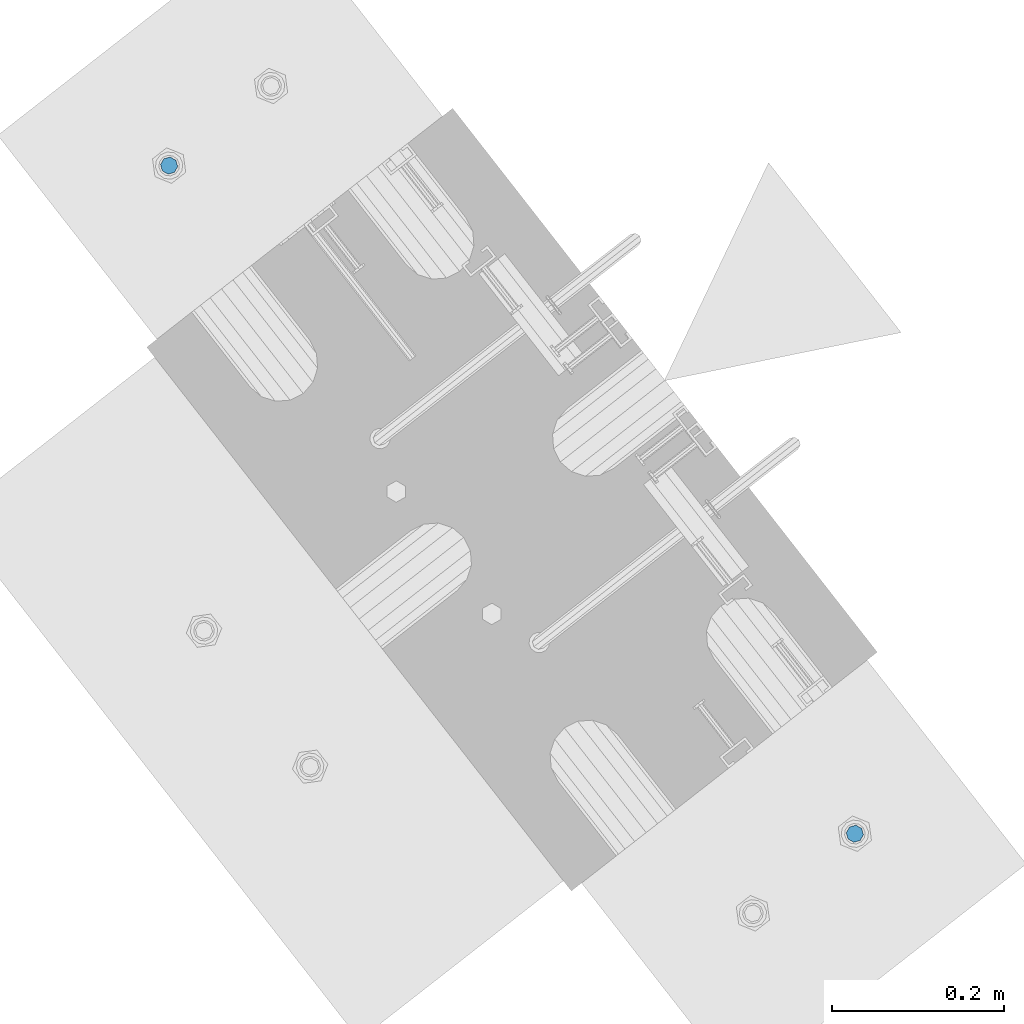
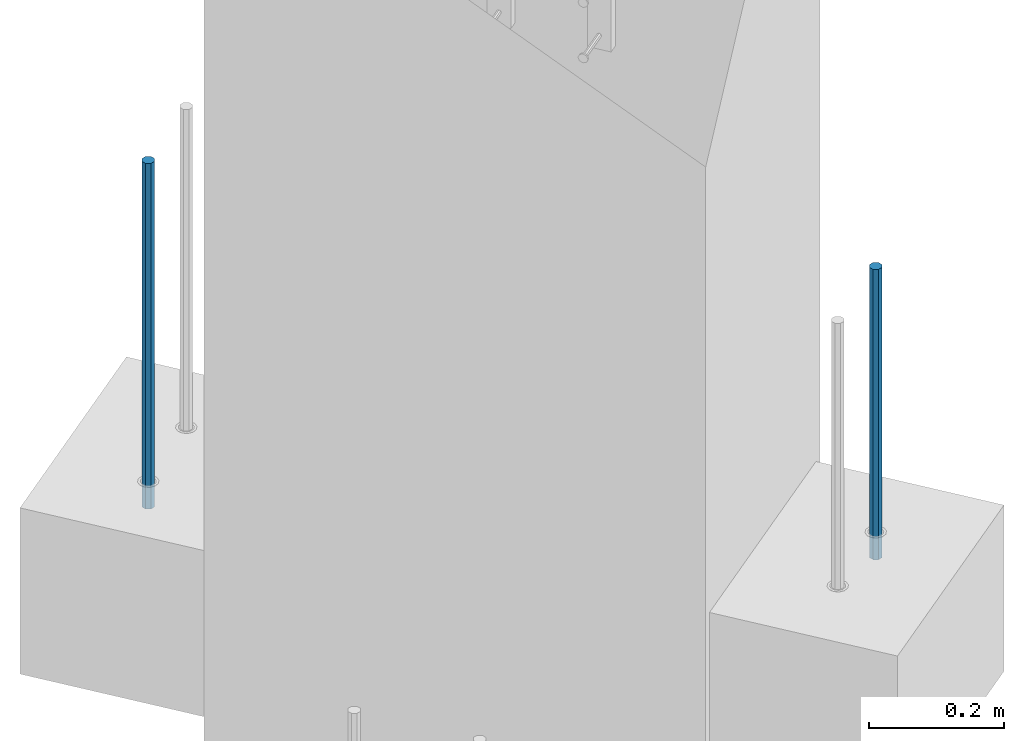
# One storey, part 10 of 42: 2 beams, 1 element without a shape of its own.
"""IFC2X3 building model written with IfcOpenShell, lengths in millimetres."""

from ifc_helpers import new_model, si_unit, frame, origin_with_axes, place, context, subcontext, project, spatial, faceted_brep, material, type_object, element, aggregate, save


model = new_model("IFC2X3")

# Units and contexts
model_context = context("Model", 3, precision=1e-05, world=origin_with_axes())
body_context = subcontext(model_context, "Body", "Model", "MODEL_VIEW")
ifc_project = project(units=[si_unit("LENGTHUNIT", "METRE", prefix="MILLI"), si_unit("AREAUNIT", "SQUARE_METRE"), si_unit("VOLUMEUNIT", "CUBIC_METRE"), si_unit("MASSUNIT", "GRAM", prefix="KILO"), si_unit("TIMEUNIT", "SECOND"), si_unit("PLANEANGLEUNIT", "RADIAN"), si_unit("SOLIDANGLEUNIT", "STERADIAN"), si_unit("THERMODYNAMICTEMPERATUREUNIT", "DEGREE_CELSIUS"), si_unit("LUMINOUSINTENSITYUNIT", "LUMEN")], contexts=[model_context])

# Site, building, storey
site_placement = place(None, frame((171687.4, 84828.52, 14700.0), z_axis=(0.0, 0.0, 1.0), x_axis=(1.0, 0.0, 0.0)))
site = spatial("IfcSite", under=ifc_project, at=site_placement, CompositionType="ELEMENT")
building_placement = place(site_placement, origin_with_axes())
building = spatial("IfcBuilding", under=site, at=building_placement, Name="Undefined", CompositionType="ELEMENT")
storey_placement = place(building_placement, origin_with_axes())
storey = spatial("IfcBuildingStorey", under=building, at=storey_placement, Name="Undefined", CompositionType="ELEMENT", Elevation=0.0)

# Assembly, beams
assembly_placement = place(storey_placement, origin_with_axes())
assembly = element("IfcElementAssembly", 1, at=assembly_placement, inside=storey, AssemblyPlace="NOTDEFINED", PredefinedType="REINFORCEMENT_UNIT")
ifc_material = material(Name="STEEL/S235JR")
beam_type = type_object("IfcBeamType", PredefinedType="NOTDEFINED")
beam_1_placement = place(assembly_placement, frame((18494.3650953644, 264961.918298424, 6229.99999999999), z_axis=(0.615386370178831, -0.788225611990706, 0.0), x_axis=(0.0, 0.0, -1.0)))
beam_1 = element("IfcBeam", 2, at=beam_1_placement, type_object=beam_type, material=ifc_material, context=body_context, shape_type="Brep", body=[
    faceted_brep([(4.88085788674653e-07, -10.0, -3.86498868465424e-08), (0.0, -7.07106819456385, -7.07106766643119), (524.0, -7.07106759562157, -7.07106811032281), (524.0, -9.99999978375854, -2.98430677503347e-07), (4.97872867461239e-11, -3.88578058618805e-15, -10.0), (524.0, 2.16212356463075e-07, -10.000000298518), (0.0, 7.07106742914766, -7.0710676664894), (524.0, 7.07106802810449, -7.07106811041012), (4.88085788674653e-07, 10.0, -3.86498868465424e-08), (524.0, 10.0000002162415, -2.98547092825174e-07), (0.0, 7.07106742919132, 7.07106795720756), (524.0, 7.0710680281336, 7.07106751331594), (-4.97872867461239e-11, 0.0, 10.0), (524.0, 2.16299667954445e-07, 9.99999970148201), (0.0, -7.07106819453475, 7.07106795729487), (524.0, -7.07106759559247, 7.07106751340325)], [[[0, 1, 2, 3]], [[1, 4, 5, 2]], [[4, 6, 7, 5]], [[6, 8, 9, 7]], [[8, 10, 11, 9]], [[10, 12, 13, 11]], [[12, 14, 15, 13]], [[14, 0, 3, 15]], [[5, 7, 9, 11, 13, 15, 3, 2]], [[14, 12, 10, 8, 6, 4, 1, 0]]]),
])
beam_2_placement = place(assembly_placement, frame((17699.206246375, 265736.658516089, 6230.0), z_axis=(-0.615386219627735, 0.788225729529483, 0.0), x_axis=(0.0, 0.0, -1.0)))
beam_2 = element("IfcBeam", 3, at=beam_2_placement, type_object=beam_type, material=ifc_material, context=body_context, shape_type="Brep", body=[
    faceted_brep([(4.88085788674653e-07, -10.0, -3.86498868465424e-08), (0.0, -7.07106819456385, -7.07106766643119), (624.0, -7.0710680251359, -7.07106751203537), (624.0, -10.0000002132438, 2.99856765195727e-07), (4.97872867461239e-11, -3.88578058618805e-15, -10.0), (624.0, -2.13272869586945e-07, -9.99999970020144), (0.0, 7.07106742914766, -7.0710676664894), (624.0, 7.07106759861927, -7.07106751209358), (4.88085788674653e-07, 10.0, -3.86498868465424e-08), (624.0, 9.99999978675623, 2.99711246043444e-07), (0.0, 7.07106742919132, 7.07106795720756), (624.0, 7.07106759864837, 7.07106811160338), (-4.97872867461239e-11, 0.0, 10.0), (624.0, -2.13214661926031e-07, 10.0000002997695), (0.0, -7.07106819453475, 7.07106795729487), (624.0, -7.0710680251068, 7.07106811166159)], [[[0, 1, 2, 3]], [[1, 4, 5, 2]], [[4, 6, 7, 5]], [[6, 8, 9, 7]], [[8, 10, 11, 9]], [[10, 12, 13, 11]], [[12, 14, 15, 13]], [[14, 0, 3, 15]], [[5, 7, 9, 11, 13, 15, 3, 2]], [[14, 12, 10, 8, 6, 4, 1, 0]]]),
])
aggregate(assembly, [beam_1, beam_2])

save(model, "model.ifc")
